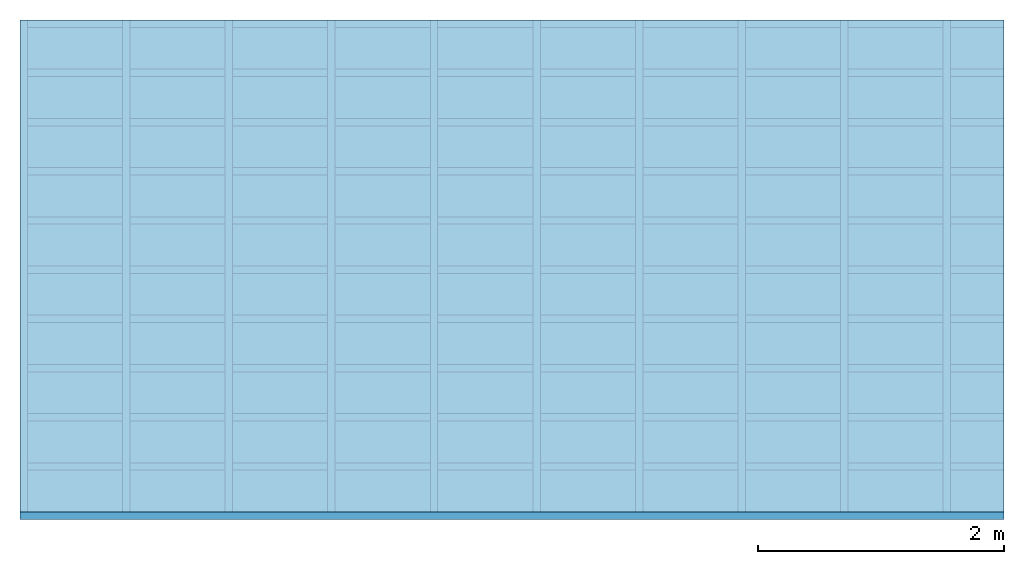
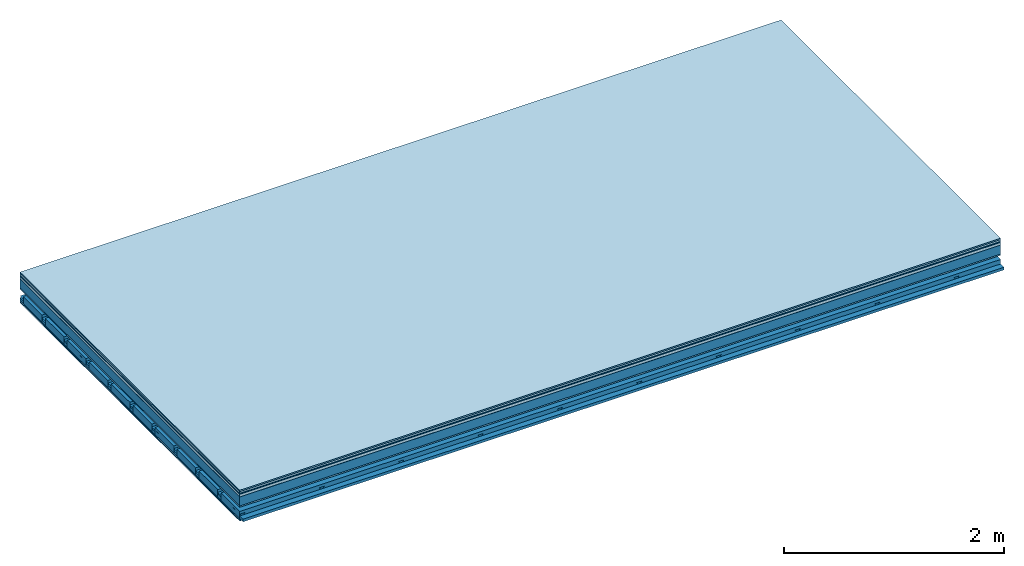
# One storey: 9 plates, 4 members, 1 element without a shape of its own.
"""IFC4 building model written with IfcOpenShell, lengths in metres."""

from ifc_helpers import new_model, si_unit, derived_unit, direction, frame, frame_2d, origin, origin_with_axes, place, context, project, spatial, polyline, rectangle, outline, extrude, material, layer, layer_set, type_object, element, aggregate, save


model = new_model("IFC4")

# Units and contexts
plan_context = context("Plan", 3, precision=1e-05, world=origin(), true_north=direction((0.0, 1.0)))
model_context = context("Model", 3, precision=1e-05, world=origin(), true_north=direction((0.0, 1.0)))
ifc_project = project(units=[si_unit("LENGTHUNIT", "METRE"), derived_unit("SOUNDPRESSUREUNIT", [(si_unit("PRESSUREUNIT", "PASCAL", prefix="MICRO"), 0)]), si_unit("ENERGYUNIT", "JOULE", prefix="MEGA"), si_unit("MASSUNIT", "GRAM", prefix="KILO"), derived_unit("THERMALTRANSMITTANCEUNIT", [(si_unit("POWERUNIT", "WATT"), 1), (si_unit("AREAUNIT", "SQUARE_METRE"), -1), (si_unit("THERMODYNAMICTEMPERATUREUNIT", "KELVIN"), -1)]), derived_unit("AREADENSITYUNIT", [(si_unit("MASSUNIT", "GRAM", prefix="KILO"), 1), (si_unit("AREAUNIT", "SQUARE_METRE"), -1)]), derived_unit("USERDEFINED", [(si_unit("ENERGYUNIT", "JOULE", prefix="MEGA"), 1), (si_unit("AREAUNIT", "SQUARE_METRE"), -1)])], contexts=[plan_context, model_context])

# Site, building, storey
site = spatial("IfcSite", under=ifc_project)
building_placement = place(None, origin())
building = spatial("IfcBuilding", under=site, at=building_placement)
storey_placement = place(building_placement, origin())
storey = spatial("IfcBuildingStorey", under=building, at=storey_placement)

# Slab, members, plates
ifc_material_1 = material(Category="11.013")
ifc_layer_1 = layer(ifc_material_1, 0.015, Name="Flooring")
ifc_material_2 = material(Category="03.007")
ifc_layer_2 = layer(ifc_material_2, 0.02, Name="On-material")
ifc_material_3 = material(Name="Wood fiber generic product", Category="10.009")
ifc_layer_3 = layer(ifc_material_3, 0.01, Name="Impact sound insulation")
ifc_material_4 = material(Name="with broken")
ifc_layer_4 = layer(ifc_material_4, 0.03, Name="on Supporting structure")
ifc_material_5 = material(Name="protection", Category="09.007")
ifc_layer_5 = layer(ifc_material_5, 0.0005, Name="Sub-floor")
ifc_material_6 = material(Name="no composite action")
ifc_layer_6 = layer(ifc_material_6, 0.0, Name="Bond")
ifc_layer_7 = layer(None, 0.1, Name="Supporting structure")
ifc_material_7 = material(Name="of the art")
ifc_layer_8 = layer(ifc_material_7, 0.0, Name="Bond")
ifc_layer_9 = layer(ifc_material_2, 0.015, Name="Lower layer 1")
ifc_layer_10 = layer(None, 0.095, Name="Coupling")
ifc_layer_11 = layer(None, 0.03, Name="Battens / profiles")
ifc_material_8 = material(Name="Plasterboard type A", Category="03.008")
ifc_layer_12 = layer(ifc_material_8, 0.0125, Name="Ceiling covering 1st layer")
ifc_layer_13 = layer(ifc_material_8, 0.0125, Name="Ceiling covering layer 2")
ifc_material_9 = material(Category="04.001")
ifc_layer_14 = layer(ifc_material_9, 0.003, Name="Surface / treatment")
ifc_layer_set = layer_set([ifc_layer_1, ifc_layer_2, ifc_layer_3, ifc_layer_4, ifc_layer_5, ifc_layer_6, ifc_layer_7, ifc_layer_8, ifc_layer_9, ifc_layer_10, ifc_layer_11, ifc_layer_12, ifc_layer_13, ifc_layer_14])
slab_type = type_object("IfcSlabType", Name="A2122", PredefinedType="NOTDEFINED", material=ifc_layer_set)
slab_placement = place(None, frame((0.0, 0.0, 0.0), z_axis=(0.0, 0.0, -1.0), x_axis=(1.0, 0.0, 0.0)))
slab = element("IfcSlab", 1, at=slab_placement, inside=storey, type_object=slab_type, material=ifc_layer_set, Name="Slab #1")
ifc_material_10 = material(Name="Solid timber panel")
member_1_placement = place(slab_placement, origin())
member_1 = element("IfcMember", 2, at=member_1_placement, material=ifc_material_10, Name="Supporting structure", context=plan_context, shape_type="SweptSolid", body=[
    extrude(rectangle(XDim=1.0, YDim=0.1, at=frame_2d((0.5, 0.05), x_axis=(1.0, 0.0))), frame((0.0, 4.0, 0.0755), z_axis=(0.0, -1.0, 0.0), x_axis=(1.0, 0.0, 0.0)), (0.0, 0.0, 1.0), 4.0),
    extrude(rectangle(XDim=1.0, YDim=0.1, at=frame_2d((0.5, 0.05), x_axis=(1.0, 0.0))), frame((1.0, 4.0, 0.0755), z_axis=(0.0, -1.0, 0.0), x_axis=(1.0, 0.0, 0.0)), (0.0, 0.0, 1.0), 4.0),
    extrude(rectangle(XDim=1.0, YDim=0.1, at=frame_2d((0.5, 0.05), x_axis=(1.0, 0.0))), frame((2.0, 4.0, 0.0755), z_axis=(0.0, -1.0, 0.0), x_axis=(1.0, 0.0, 0.0)), (0.0, 0.0, 1.0), 4.0),
    extrude(rectangle(XDim=1.0, YDim=0.1, at=frame_2d((0.5, 0.05), x_axis=(1.0, 0.0))), frame((3.0, 4.0, 0.0755), z_axis=(0.0, -1.0, 0.0), x_axis=(1.0, 0.0, 0.0)), (0.0, 0.0, 1.0), 4.0),
    extrude(rectangle(XDim=1.0, YDim=0.1, at=frame_2d((0.5, 0.05), x_axis=(1.0, 0.0))), frame((4.0, 4.0, 0.0755), z_axis=(0.0, -1.0, 0.0), x_axis=(1.0, 0.0, 0.0)), (0.0, 0.0, 1.0), 4.0),
    extrude(rectangle(XDim=1.0, YDim=0.1, at=frame_2d((0.5, 0.05), x_axis=(1.0, 0.0))), frame((5.0, 4.0, 0.0755), z_axis=(0.0, -1.0, 0.0), x_axis=(1.0, 0.0, 0.0)), (0.0, 0.0, 1.0), 4.0),
    extrude(rectangle(XDim=1.0, YDim=0.1, at=frame_2d((0.5, 0.05), x_axis=(1.0, 0.0))), frame((6.0, 4.0, 0.0755), z_axis=(0.0, -1.0, 0.0), x_axis=(1.0, 0.0, 0.0)), (0.0, 0.0, 1.0), 4.0),
    extrude(rectangle(XDim=1.0, YDim=0.1, at=frame_2d((0.5, 0.05), x_axis=(1.0, 0.0))), frame((7.0, 4.0, 0.0755), z_axis=(0.0, -1.0, 0.0), x_axis=(1.0, 0.0, 0.0)), (0.0, 0.0, 1.0), 4.0),
])
ifc_material_11 = material()
member_2_placement = place(slab_placement, origin())
member_2 = element("IfcMember", 3, at=member_2_placement, material=ifc_material_11, Name="Coupling", context=plan_context, shape_type="SweptSolid", body=[
    extrude(outline(polyline([(0.0, 0.0), (0.06, 0.0), (0.04, 0.02), (0.02, 0.02), (0.0, 0.0)])), frame((0.0, 4.0, 0.2655), z_axis=(0.0, -1.0, 0.0), x_axis=(1.0, 0.0, 0.0)), (0.0, 0.0, 1.0), 4.0),
    extrude(outline(polyline([(0.0, 0.0), (0.06, 0.0), (0.04, 0.02), (0.02, 0.02), (0.0, 0.0)])), frame((0.834, 4.0, 0.2655), z_axis=(0.0, -1.0, 0.0), x_axis=(1.0, 0.0, 0.0)), (0.0, 0.0, 1.0), 4.0),
    extrude(outline(polyline([(0.0, 0.0), (0.06, 0.0), (0.04, 0.02), (0.02, 0.02), (0.0, 0.0)])), frame((1.668, 4.0, 0.2655), z_axis=(0.0, -1.0, 0.0), x_axis=(1.0, 0.0, 0.0)), (0.0, 0.0, 1.0), 4.0),
    extrude(outline(polyline([(0.0, 0.0), (0.06, 0.0), (0.04, 0.02), (0.02, 0.02), (0.0, 0.0)])), frame((2.502, 4.0, 0.2655), z_axis=(0.0, -1.0, 0.0), x_axis=(1.0, 0.0, 0.0)), (0.0, 0.0, 1.0), 4.0),
    extrude(outline(polyline([(0.0, 0.0), (0.06, 0.0), (0.04, 0.02), (0.02, 0.02), (0.0, 0.0)])), frame((3.336, 4.0, 0.2655), z_axis=(0.0, -1.0, 0.0), x_axis=(1.0, 0.0, 0.0)), (0.0, 0.0, 1.0), 4.0),
    extrude(outline(polyline([(0.0, 0.0), (0.06, 0.0), (0.04, 0.02), (0.02, 0.02), (0.0, 0.0)])), frame((4.17, 4.0, 0.2655), z_axis=(0.0, -1.0, 0.0), x_axis=(1.0, 0.0, 0.0)), (0.0, 0.0, 1.0), 4.0),
    extrude(outline(polyline([(0.0, 0.0), (0.06, 0.0), (0.04, 0.02), (0.02, 0.02), (0.0, 0.0)])), frame((5.004, 4.0, 0.2655), z_axis=(0.0, -1.0, 0.0), x_axis=(1.0, 0.0, 0.0)), (0.0, 0.0, 1.0), 4.0),
    extrude(outline(polyline([(0.0, 0.0), (0.06, 0.0), (0.04, 0.02), (0.02, 0.02), (0.0, 0.0)])), frame((5.838, 4.0, 0.2655), z_axis=(0.0, -1.0, 0.0), x_axis=(1.0, 0.0, 0.0)), (0.0, 0.0, 1.0), 4.0),
    extrude(outline(polyline([(0.0, 0.0), (0.06, 0.0), (0.04, 0.02), (0.02, 0.02), (0.0, 0.0)])), frame((6.672, 4.0, 0.2655), z_axis=(0.0, -1.0, 0.0), x_axis=(1.0, 0.0, 0.0)), (0.0, 0.0, 1.0), 4.0),
    extrude(outline(polyline([(0.0, 0.0), (0.06, 0.0), (0.04, 0.02), (0.02, 0.02), (0.0, 0.0)])), frame((7.506, 4.0, 0.2655), z_axis=(0.0, -1.0, 0.0), x_axis=(1.0, 0.0, 0.0)), (0.0, 0.0, 1.0), 4.0),
])
member_3_placement = place(slab_placement, origin())
member_3 = element("IfcMember", 4, at=member_3_placement, material=ifc_material_11, Name="Battens / profiles", context=plan_context, shape_type="SweptSolid", body=[
    extrude(rectangle(XDim=0.06, YDim=0.03, at=frame_2d((0.03, 0.015), x_axis=(1.0, 0.0))), frame((0.0, 0.0, 0.2855), z_axis=(1.0, 0.0, 0.0), x_axis=(0.0, 1.0, 0.0)), (0.0, 0.0, 1.0), 8.0),
    extrude(rectangle(XDim=0.06, YDim=0.03, at=frame_2d((0.03, 0.015), x_axis=(1.0, 0.0))), frame((0.0, 0.4, 0.2855), z_axis=(1.0, 0.0, 0.0), x_axis=(0.0, 1.0, 0.0)), (0.0, 0.0, 1.0), 8.0),
    extrude(rectangle(XDim=0.06, YDim=0.03, at=frame_2d((0.03, 0.015), x_axis=(1.0, 0.0))), frame((0.0, 0.8, 0.2855), z_axis=(1.0, 0.0, 0.0), x_axis=(0.0, 1.0, 0.0)), (0.0, 0.0, 1.0), 8.0),
    extrude(rectangle(XDim=0.06, YDim=0.03, at=frame_2d((0.03, 0.015), x_axis=(1.0, 0.0))), frame((0.0, 1.2, 0.2855), z_axis=(1.0, 0.0, 0.0), x_axis=(0.0, 1.0, 0.0)), (0.0, 0.0, 1.0), 8.0),
    extrude(rectangle(XDim=0.06, YDim=0.03, at=frame_2d((0.03, 0.015), x_axis=(1.0, 0.0))), frame((0.0, 1.6, 0.2855), z_axis=(1.0, 0.0, 0.0), x_axis=(0.0, 1.0, 0.0)), (0.0, 0.0, 1.0), 8.0),
    extrude(rectangle(XDim=0.06, YDim=0.03, at=frame_2d((0.03, 0.015), x_axis=(1.0, 0.0))), frame((0.0, 2.0, 0.2855), z_axis=(1.0, 0.0, 0.0), x_axis=(0.0, 1.0, 0.0)), (0.0, 0.0, 1.0), 8.0),
    extrude(rectangle(XDim=0.06, YDim=0.03, at=frame_2d((0.03, 0.015), x_axis=(1.0, 0.0))), frame((0.0, 2.4, 0.2855), z_axis=(1.0, 0.0, 0.0), x_axis=(0.0, 1.0, 0.0)), (0.0, 0.0, 1.0), 8.0),
    extrude(rectangle(XDim=0.06, YDim=0.03, at=frame_2d((0.03, 0.015), x_axis=(1.0, 0.0))), frame((0.0, 2.8, 0.2855), z_axis=(1.0, 0.0, 0.0), x_axis=(0.0, 1.0, 0.0)), (0.0, 0.0, 1.0), 8.0),
    extrude(rectangle(XDim=0.06, YDim=0.03, at=frame_2d((0.03, 0.015), x_axis=(1.0, 0.0))), frame((0.0, 3.2, 0.2855), z_axis=(1.0, 0.0, 0.0), x_axis=(0.0, 1.0, 0.0)), (0.0, 0.0, 1.0), 8.0),
    extrude(rectangle(XDim=0.06, YDim=0.03, at=frame_2d((0.03, 0.015), x_axis=(1.0, 0.0))), frame((0.0, 3.6, 0.2855), z_axis=(1.0, 0.0, 0.0), x_axis=(0.0, 1.0, 0.0)), (0.0, 0.0, 1.0), 8.0),
    extrude(rectangle(XDim=0.06, YDim=0.03, at=frame_2d((0.03, 0.015), x_axis=(1.0, 0.0))), frame((0.0, 4.0, 0.2855), z_axis=(1.0, 0.0, 0.0), x_axis=(0.0, 1.0, 0.0)), (0.0, 0.0, 1.0), 8.0),
])
ifc_material_12 = material()
member_4_placement = place(slab_placement, origin())
member_4 = element("IfcMember", 5, at=member_4_placement, material=ifc_material_12, Name="Cavity", context=plan_context, shape_type="SweptSolid", body=[
    extrude(rectangle(XDim=0.34, YDim=0.08, at=frame_2d((0.17, 0.04), x_axis=(1.0, 0.0))), frame((0.0, 0.06, 0.2355), z_axis=(1.0, 0.0, 0.0), x_axis=(0.0, 1.0, 0.0)), (0.0, 0.0, 1.0), 8.0),
    extrude(rectangle(XDim=0.34, YDim=0.08, at=frame_2d((0.17, 0.04), x_axis=(1.0, 0.0))), frame((0.0, 0.46, 0.2355), z_axis=(1.0, 0.0, 0.0), x_axis=(0.0, 1.0, 0.0)), (0.0, 0.0, 1.0), 8.0),
    extrude(rectangle(XDim=0.34, YDim=0.08, at=frame_2d((0.17, 0.04), x_axis=(1.0, 0.0))), frame((0.0, 0.86, 0.2355), z_axis=(1.0, 0.0, 0.0), x_axis=(0.0, 1.0, 0.0)), (0.0, 0.0, 1.0), 8.0),
    extrude(rectangle(XDim=0.34, YDim=0.08, at=frame_2d((0.17, 0.04), x_axis=(1.0, 0.0))), frame((0.0, 1.26, 0.2355), z_axis=(1.0, 0.0, 0.0), x_axis=(0.0, 1.0, 0.0)), (0.0, 0.0, 1.0), 8.0),
    extrude(rectangle(XDim=0.34, YDim=0.08, at=frame_2d((0.17, 0.04), x_axis=(1.0, 0.0))), frame((0.0, 1.66, 0.2355), z_axis=(1.0, 0.0, 0.0), x_axis=(0.0, 1.0, 0.0)), (0.0, 0.0, 1.0), 8.0),
    extrude(rectangle(XDim=0.34, YDim=0.08, at=frame_2d((0.17, 0.04), x_axis=(1.0, 0.0))), frame((0.0, 2.06, 0.2355), z_axis=(1.0, 0.0, 0.0), x_axis=(0.0, 1.0, 0.0)), (0.0, 0.0, 1.0), 8.0),
    extrude(rectangle(XDim=0.34, YDim=0.08, at=frame_2d((0.17, 0.04), x_axis=(1.0, 0.0))), frame((0.0, 2.46, 0.2355), z_axis=(1.0, 0.0, 0.0), x_axis=(0.0, 1.0, 0.0)), (0.0, 0.0, 1.0), 8.0),
    extrude(rectangle(XDim=0.34, YDim=0.08, at=frame_2d((0.17, 0.04), x_axis=(1.0, 0.0))), frame((0.0, 2.86, 0.2355), z_axis=(1.0, 0.0, 0.0), x_axis=(0.0, 1.0, 0.0)), (0.0, 0.0, 1.0), 8.0),
    extrude(rectangle(XDim=0.34, YDim=0.08, at=frame_2d((0.17, 0.04), x_axis=(1.0, 0.0))), frame((0.0, 3.26, 0.2355), z_axis=(1.0, 0.0, 0.0), x_axis=(0.0, 1.0, 0.0)), (0.0, 0.0, 1.0), 8.0),
    extrude(rectangle(XDim=0.34, YDim=0.08, at=frame_2d((0.17, 0.04), x_axis=(1.0, 0.0))), frame((0.0, 3.66, 0.2355), z_axis=(1.0, 0.0, 0.0), x_axis=(0.0, 1.0, 0.0)), (0.0, 0.0, 1.0), 8.0),
])
plate_1_placement = place(slab_placement, origin())
plate_1 = element("IfcPlate", 6, at=plate_1_placement, material=ifc_material_1, Name="Flooring", context=plan_context, shape_type="SweptSolid", body=[
    extrude(rectangle(XDim=8.0, YDim=4.0, at=frame_2d((4.0, 2.0), x_axis=(1.0, 0.0))), origin_with_axes(), (0.0, 0.0, 1.0), 0.015),
])
plate_2_placement = place(slab_placement, origin())
plate_2 = element("IfcPlate", 7, at=plate_2_placement, material=ifc_material_2, Name="On-material", context=plan_context, shape_type="SweptSolid", body=[
    extrude(rectangle(XDim=8.0, YDim=4.0, at=frame_2d((4.0, 2.0), x_axis=(1.0, 0.0))), frame((0.0, 0.0, 0.015), z_axis=(0.0, 0.0, 1.0), x_axis=(1.0, 0.0, 0.0)), (0.0, 0.0, 1.0), 0.02),
])
plate_3_placement = place(slab_placement, origin())
plate_3 = element("IfcPlate", 8, at=plate_3_placement, material=ifc_material_3, Name="Impact sound insulation", context=plan_context, shape_type="SweptSolid", body=[
    extrude(rectangle(XDim=8.0, YDim=4.0, at=frame_2d((4.0, 2.0), x_axis=(1.0, 0.0))), frame((0.0, 0.0, 0.035), z_axis=(0.0, 0.0, 1.0), x_axis=(1.0, 0.0, 0.0)), (0.0, 0.0, 1.0), 0.01),
])
plate_4_placement = place(slab_placement, origin())
plate_4 = element("IfcPlate", 9, at=plate_4_placement, material=ifc_material_4, Name="on Supporting structure", context=plan_context, shape_type="SweptSolid", body=[
    extrude(rectangle(XDim=8.0, YDim=4.0, at=frame_2d((4.0, 2.0), x_axis=(1.0, 0.0))), frame((0.0, 0.0, 0.045), z_axis=(0.0, 0.0, 1.0), x_axis=(1.0, 0.0, 0.0)), (0.0, 0.0, 1.0), 0.03),
])
plate_5_placement = place(slab_placement, origin())
plate_5 = element("IfcPlate", 10, at=plate_5_placement, material=ifc_material_5, Name="Sub-floor", context=plan_context, shape_type="SweptSolid", body=[
    extrude(rectangle(XDim=8.0, YDim=4.0, at=frame_2d((4.0, 2.0), x_axis=(1.0, 0.0))), frame((0.0, 0.0, 0.075), z_axis=(0.0, 0.0, 1.0), x_axis=(1.0, 0.0, 0.0)), (0.0, 0.0, 1.0), 0.0005),
])
plate_6_placement = place(slab_placement, origin())
plate_6 = element("IfcPlate", 11, at=plate_6_placement, material=ifc_material_2, Name="Lower layer 1", context=plan_context, shape_type="SweptSolid", body=[
    extrude(rectangle(XDim=8.0, YDim=4.0, at=frame_2d((4.0, 2.0), x_axis=(1.0, 0.0))), frame((0.0, 0.0, 0.1755), z_axis=(0.0, 0.0, 1.0), x_axis=(1.0, 0.0, 0.0)), (0.0, 0.0, 1.0), 0.015),
])
plate_7_placement = place(slab_placement, origin())
plate_7 = element("IfcPlate", 12, at=plate_7_placement, material=ifc_material_8, Name="Ceiling covering 1st layer", context=plan_context, shape_type="SweptSolid", body=[
    extrude(rectangle(XDim=8.0, YDim=4.0, at=frame_2d((4.0, 2.0), x_axis=(1.0, 0.0))), frame((0.0, 0.0, 0.3155), z_axis=(0.0, 0.0, 1.0), x_axis=(1.0, 0.0, 0.0)), (0.0, 0.0, 1.0), 0.0125),
])
plate_8_placement = place(slab_placement, origin())
plate_8 = element("IfcPlate", 13, at=plate_8_placement, material=ifc_material_8, Name="Ceiling covering layer 2", context=plan_context, shape_type="SweptSolid", body=[
    extrude(rectangle(XDim=8.0, YDim=4.0, at=frame_2d((4.0, 2.0), x_axis=(1.0, 0.0))), frame((0.0, 0.0, 0.328), z_axis=(0.0, 0.0, 1.0), x_axis=(1.0, 0.0, 0.0)), (0.0, 0.0, 1.0), 0.0125),
])
plate_9_placement = place(slab_placement, origin())
plate_9 = element("IfcPlate", 14, at=plate_9_placement, material=ifc_material_9, Name="Surface / treatment", context=plan_context, shape_type="SweptSolid", body=[
    extrude(rectangle(XDim=8.0, YDim=4.0, at=frame_2d((4.0, 2.0), x_axis=(1.0, 0.0))), frame((0.0, 0.0, 0.3405), z_axis=(0.0, 0.0, 1.0), x_axis=(1.0, 0.0, 0.0)), (0.0, 0.0, 1.0), 0.003),
])
aggregate(slab, [plate_1, plate_2, plate_3, plate_4, plate_5, member_1, plate_6, member_2, member_3, member_4, plate_7, plate_8, plate_9])

save(model, "model.ifc")
